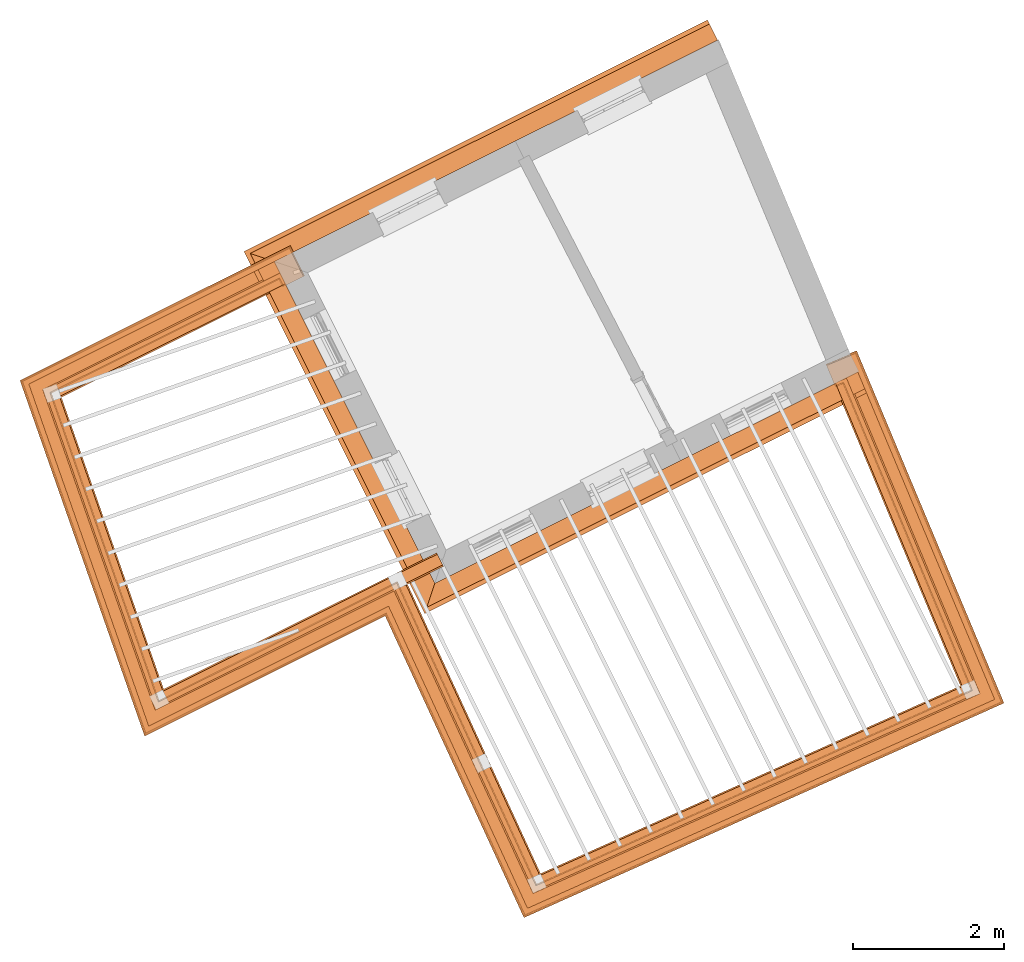
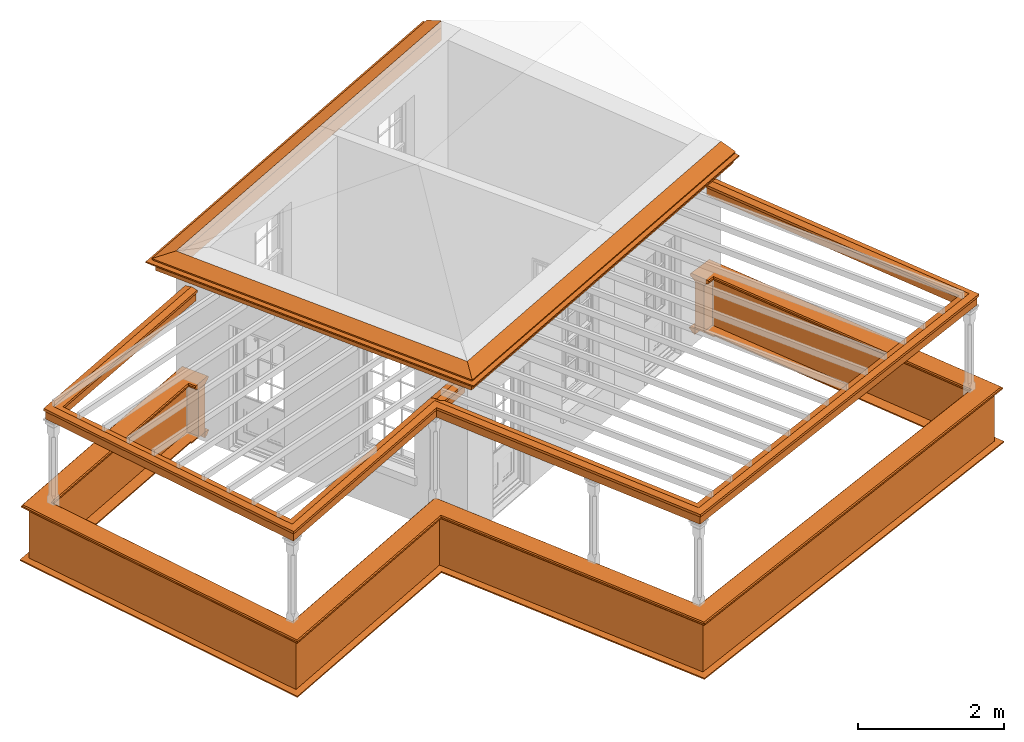
# One storey, part 6 of 7: 9 proxies.
"""IFC2X3 building model written with IfcOpenShell, lengths in metres."""

import ifcopenshell
import ifcopenshell.guid

model = None  # the IFC model being written
_history = None  # IfcOwnerHistory: only IFC2X3 demands one
_inside = {}  # id of a spatial element -> (the spatial element, [elements in it])
_under = {}  # id of a project, library or spatial element -> (it, [spatial elements below it])
_declared = {}  # id of a project -> (the project, [libraries it declares])
_typed = {}  # id of a type object -> (the type object, [elements of that type])
_made_of = {}  # id of a material, layer set ... -> (it, [elements and type objects made of it])


def new_model(schema):
    """Start an empty IFC model of exactly this schema.

    Asked for "IFC4X3", IfcOpenShell would pick the latest addendum, in which some entities
    have other attributes; the version numbers below select the first issue.
    IFC2X3 requires an IfcOwnerHistory on every rooted entity: one is made here for all.
    """
    global model, _history
    if schema == "IFC4X3":
        model = ifcopenshell.file(schema_version=(4, 3, 0, 0))
    else:
        model = ifcopenshell.file(schema=schema)
    _inside.clear()
    _under.clear()
    _declared.clear()
    _typed.clear()
    _made_of.clear()
    _history = None
    if model.schema == "IFC2X3":
        org = make("IfcOrganization", Name="unknown")
        user = make(
            "IfcPersonAndOrganization",
            ThePerson=make("IfcPerson", FamilyName="unknown"),
            TheOrganization=org,
        )
        app = make(
            "IfcApplication",
            ApplicationDeveloper=org,
            Version="unknown",
            ApplicationFullName="unknown",
            ApplicationIdentifier="unknown",
        )
        _history = make(
            "IfcOwnerHistory",
            OwningUser=user,
            OwningApplication=app,
            ChangeAction="ADDED",
            CreationDate=0,
        )
    return model


def make(cls, **values):
    """One entity of the class cls with the attributes given. An attribute that is None is left unset."""
    return model.create_entity(
        cls, **{name: value for name, value in values.items() if value is not None}
    )


def entity(cls, *values):
    """Any entity or typed value of the class cls, its attributes in the order of the schema. None: left unset."""
    e = model.create_entity(cls)
    for i, value in enumerate(values):
        if value is not None:
            e[i] = value
    return e


def rooted(cls, **values):
    """An entity with a GlobalId (a new one), such as an element, a storey or a relation."""
    return make(cls, GlobalId=ifcopenshell.guid.new(), OwnerHistory=_history, **values)


def si_unit(unit_type, name, prefix=None):
    """IfcSIUnit, for example si_unit("LENGTHUNIT", "METRE", prefix="MILLI")."""
    return make("IfcSIUnit", UnitType=unit_type, Prefix=prefix, Name=name)


def assignment(units):
    """IfcUnitAssignment: the units of a project."""
    return None if units is None else make("IfcUnitAssignment", Units=units)


def point(xyz):
    """IfcCartesianPoint."""
    return None if xyz is None else make("IfcCartesianPoint", Coordinates=xyz)


def direction(xyz):
    """IfcDirection."""
    return None if xyz is None else make("IfcDirection", DirectionRatios=xyz)


def frame(location, z_axis=None, x_axis=None):
    """IfcAxis2Placement3D, a coordinate frame: its origin and axes. An axis left out is left unset."""
    return make(
        "IfcAxis2Placement3D",
        Location=point(location),
        Axis=direction(z_axis),
        RefDirection=direction(x_axis),
    )


def origin():
    """The frame at (0, 0, 0) with its axes left unset."""
    return frame((0.0, 0.0, 0.0))


def place(relative_to, where):
    """IfcLocalPlacement: puts the frame where relative to a parent placement (None: the world)."""
    return make(
        "IfcLocalPlacement", PlacementRelTo=relative_to, RelativePlacement=where
    )


def context(
    kind, dimensions, precision=None, world=None, true_north=None, identifier=None
):
    """IfcGeometricRepresentationContext, for example the 3D "Model" context."""
    return make(
        "IfcGeometricRepresentationContext",
        ContextIdentifier=identifier,
        ContextType=kind,
        CoordinateSpaceDimension=dimensions,
        Precision=precision,
        WorldCoordinateSystem=world,
        TrueNorth=true_north,
    )


def subcontext(parent, identifier, kind, view, scale=None):
    """IfcGeometricRepresentationSubContext, for example "Body" below "Model"."""
    return make(
        "IfcGeometricRepresentationSubContext",
        ContextIdentifier=identifier,
        ContextType=kind,
        ParentContext=parent,
        TargetScale=scale,
        TargetView=view,
    )


def project(units=None, contexts=None):
    """IfcProject with its units and contexts."""
    return rooted(
        "IfcProject",
        Name="project",
        RepresentationContexts=contexts,
        UnitsInContext=assignment(units),
    )


def spatial(cls, under=None, at=None, **own):
    """A site, building, storey or space (cls), placed at a placement, below another one or the project."""
    s = rooted(cls, ObjectPlacement=at, **own)
    if under is not None:
        _under.setdefault(under.id(), (under, []))[1].append(s)
    return s


def shape(context_of_items, identifier, shape_type, items):
    """IfcShapeRepresentation: the items that make up one representation, for example the "Body"."""
    return make(
        "IfcShapeRepresentation",
        ContextOfItems=context_of_items,
        RepresentationIdentifier=identifier,
        RepresentationType=shape_type,
        Items=items,
    )


def made_of(thing, what):
    """Note that an element or type object is made of a material, layer set ...; save() writes the relation."""
    if what is not None:
        _made_of.setdefault(what.id(), (what, []))[1].append(thing)
    return thing


def element(
    cls,
    number,
    at=None,
    inside=None,
    cuts=None,
    type_object=None,
    material=None,
    context=None,
    identifier="Body",
    shape_type=None,
    held_by="IfcProductDefinitionShape",
    body=None,
    shapes=None,
    **own,
):
    """One element of the class cls, such as IfcWall. Its Tag is "e" and its number.

    at: its placement. inside: the storey or other place that contains it. cuts: it is an
    opening in that element (IfcRelVoidsElement). A single representation is given by context,
    identifier, shape_type and body (its items); several are given by shapes. held_by: the class
    of the entity that holds the representations. save() writes the other relations.
    """
    e = rooted(cls, Tag="e%d" % number, ObjectPlacement=at, **own)
    if body is not None:
        shapes = [shape(context, identifier, shape_type, body)]
    if shapes is not None:
        e.Representation = make(held_by, Representations=shapes)
    if inside is not None:
        _inside.setdefault(inside.id(), (inside, []))[1].append(e)
    if cuts is not None:
        rooted(
            "IfcRelVoidsElement", RelatingBuildingElement=cuts, RelatedOpeningElement=e
        )
    if type_object is not None:
        _typed.setdefault(type_object.id(), (type_object, []))[1].append(e)
    return made_of(e, material)


def aggregate(whole, parts):
    """IfcRelAggregates: a whole, such as a stair, and the parts it consists of."""
    return rooted("IfcRelAggregates", RelatingObject=whole, RelatedObjects=parts)


def save(model, path):
    """Write the relations noted so far, then the file.

    IfcRelAggregates (storeys below a building ...), IfcRelContainedInSpatialStructure (elements
    in a storey), IfcRelDefinesByType, IfcRelAssociatesMaterial and IfcRelDeclares: one each for
    every whole, place, type object, material and project.
    """
    for whole, parts in _under.values():
        aggregate(whole, parts)
    for where, things in _inside.values():
        rooted(
            "IfcRelContainedInSpatialStructure",
            RelatedElements=things,
            RelatingStructure=where,
        )
    for kind, things in _typed.values():
        rooted("IfcRelDefinesByType", RelatedObjects=things, RelatingType=kind)
    for what, things in _made_of.values():
        rooted("IfcRelAssociatesMaterial", RelatedObjects=things, RelatingMaterial=what)
    for by, libraries in _declared.values():
        rooted("IfcRelDeclares", RelatingContext=by, RelatedDefinitions=libraries)
    model.write(path)


model = new_model("IFC2X3")

# Units and contexts
model_context = context("Model", 3, world=origin())
body_context = subcontext(model_context, "Body", "Model", "MODEL_VIEW")
ifc_project = project(units=[si_unit("PLANEANGLEUNIT", "RADIAN"), si_unit("MASSUNIT", "GRAM", prefix="KILO"), si_unit("FORCEUNIT", "NEWTON", prefix="KILO"), si_unit("LENGTHUNIT", "METRE")], contexts=[model_context])

# Site, building, storey
site_placement = place(None, origin())
site = spatial("IfcSite", under=ifc_project, at=site_placement, CompositionType="ELEMENT")
building_placement = place(None, origin())
building = spatial("IfcBuilding", under=site, at=building_placement, Name="Building plot-8", CompositionType="ELEMENT")
storey_placement = place(None, frame((0.0, 0.0, 6.3)))
storey = spatial("IfcBuildingStorey", under=building, at=storey_placement, Name="Floor 2", CompositionType="ELEMENT", Elevation=6.3)

# Proxies
proxy_1_placement = place(storey_placement, frame((0.0, 0.0, 3.0)))
axis2_placement3_d_1 = entity("IfcAxis2Placement3D", entity("IfcCartesianPoint", [0.0, 0.0, 0.0]))
element("IfcBuildingElementProxy", 1, at=proxy_1_placement, inside=storey, Name="eaves", CompositionType="ELEMENT", context=body_context, shape_type="SweptSolid", held_by="IfcProductRepresentation", body=[
    entity("IfcSurfaceCurveSweptAreaSolid", entity("IfcArbitraryClosedProfileDef", "AREA", None, entity("IfcPolyline", [entity("IfcCartesianPoint", [-0.11, 0.25]), entity("IfcCartesianPoint", [-0.33, 0.25]), entity("IfcCartesianPoint", [-0.33, 0.265]), entity("IfcCartesianPoint", [-0.318, 0.268]), entity("IfcCartesianPoint", [-0.309, 0.274]), entity("IfcCartesianPoint", [-0.303, 0.283]), entity("IfcCartesianPoint", [-0.3, 0.295]), entity("IfcCartesianPoint", [-0.285, 0.295]), entity("IfcCartesianPoint", [-0.285, 0.455]), entity("IfcCartesianPoint", [-0.205, 0.455]), entity("IfcCartesianPoint", [-0.205, 0.47]), entity("IfcCartesianPoint", [-0.19, 0.47]), entity("IfcCartesianPoint", [-0.189, 0.483]), entity("IfcCartesianPoint", [-0.186, 0.494]), entity("IfcCartesianPoint", [-0.179, 0.506]), entity("IfcCartesianPoint", [-0.17, 0.514]), entity("IfcCartesianPoint", [-0.16, 0.52]), entity("IfcCartesianPoint", [-0.149, 0.529]), entity("IfcCartesianPoint", [-0.143, 0.539]), entity("IfcCartesianPoint", [-0.14, 0.55]), entity("IfcCartesianPoint", [-0.12, 0.55]), entity("IfcCartesianPoint", [-0.11, 0.48]), entity("IfcCartesianPoint", [-0.11, 0.25])])), axis2_placement3_d_1, entity("IfcPolyline", [entity("IfcCartesianPoint", [28.16190590808, 20.0069247398743]), entity("IfcCartesianPoint", [22.4976810156354, 17.1790956715868]), entity("IfcCartesianPoint", [24.4075412546338, 13.3535893748517]), entity("IfcCartesianPoint", [29.8153964687674, 16.0534274748564])]), 0.0, 1.0, entity("IfcPlane", axis2_placement3_d_1)),
])
proxy_2_placement = place(storey_placement, frame((0.0, 0.0, 3.0)))
axis2_placement3_d_2 = entity("IfcAxis2Placement3D", entity("IfcCartesianPoint", [0.0, 0.0, 0.0]))
element("IfcBuildingElementProxy", 2, at=proxy_2_placement, inside=storey, Name="eaves", CompositionType="ELEMENT", context=body_context, shape_type="SweptSolid", held_by="IfcProductRepresentation", body=[
    entity("IfcSurfaceCurveSweptAreaSolid", entity("IfcArbitraryClosedProfileDef", "AREA", None, entity("IfcPolyline", [entity("IfcCartesianPoint", [-0.11, 0.25]), entity("IfcCartesianPoint", [-0.11, 0.48]), entity("IfcCartesianPoint", [-0.08, 0.49]), entity("IfcCartesianPoint", [0.0, 0.25]), entity("IfcCartesianPoint", [-0.11, 0.25])])), axis2_placement3_d_2, entity("IfcPolyline", [entity("IfcCartesianPoint", [28.16190590808, 20.0069247398743]), entity("IfcCartesianPoint", [22.4976810156354, 17.1790956715868]), entity("IfcCartesianPoint", [24.4075412546338, 13.3535893748517]), entity("IfcCartesianPoint", [29.8153964687674, 16.0534274748564])]), 0.0, 1.0, entity("IfcPlane", axis2_placement3_d_2)),
])
proxy_3_placement = place(storey_placement, origin())
axis2_placement3_d_3 = entity("IfcAxis2Placement3D", entity("IfcCartesianPoint", [0.0, 0.0, 0.0]))
element("IfcBuildingElementProxy", 3, at=proxy_3_placement, inside=storey, Name="parapet", CompositionType="ELEMENT", context=body_context, shape_type="SweptSolid", held_by="IfcProductRepresentation", body=[
    entity("IfcSurfaceCurveSweptAreaSolid", entity("IfcArbitraryClosedProfileDef", "AREA", None, entity("IfcPolyline", [entity("IfcCartesianPoint", [0.0, 0.25]), entity("IfcCartesianPoint", [0.795, 0.25]), entity("IfcCartesianPoint", [0.795, 0.09]), entity("IfcCartesianPoint", [0.02, 0.09]), entity("IfcCartesianPoint", [0.02, -0.08]), entity("IfcCartesianPoint", [0.0, -0.08]), entity("IfcCartesianPoint", [0.0, 0.25])])), axis2_placement3_d_3, entity("IfcPolyline", [entity("IfcCartesianPoint", [22.2649919652668, 16.951157509274]), entity("IfcCartesianPoint", [22.2203247406861, 17.0406272753867]), entity("IfcCartesianPoint", [19.2103300053526, 15.5379061141344]), entity("IfcCartesianPoint", [20.6359073827199, 11.4706246090701]), entity("IfcCartesianPoint", [23.7996751591945, 13.0501160052469]), entity("IfcCartesianPoint", [25.6491830633519, 9.02936513625309]), entity("IfcCartesianPoint", [31.4063653367344, 11.6029458586881]), entity("IfcCartesianPoint", [29.7113348769368, 15.6557650560022]), entity("IfcCartesianPoint", [29.6190786326134, 15.6171802742438])]), 0.0, 1.0, entity("IfcPlane", axis2_placement3_d_3)),
])
proxy_4_placement = place(storey_placement, origin())
axis2_placement3_d_4 = entity("IfcAxis2Placement3D", entity("IfcCartesianPoint", [0.0, 0.0, 0.0]))
element("IfcBuildingElementProxy", 4, at=proxy_4_placement, inside=storey, Name="parapet", CompositionType="ELEMENT", context=body_context, shape_type="SweptSolid", held_by="IfcProductRepresentation", body=[
    entity("IfcSurfaceCurveSweptAreaSolid", entity("IfcArbitraryClosedProfileDef", "AREA", None, entity("IfcPolyline", [entity("IfcCartesianPoint", [0.795, 0.265]), entity("IfcCartesianPoint", [0.807, 0.268]), entity("IfcCartesianPoint", [0.816, 0.274]), entity("IfcCartesianPoint", [0.822, 0.283]), entity("IfcCartesianPoint", [0.825, 0.295]), entity("IfcCartesianPoint", [0.84, 0.295]), entity("IfcCartesianPoint", [0.84, 0.305]), entity("IfcCartesianPoint", [0.842, 0.317]), entity("IfcCartesianPoint", [0.849, 0.326]), entity("IfcCartesianPoint", [0.858, 0.333]), entity("IfcCartesianPoint", [0.87, 0.335]), entity("IfcCartesianPoint", [0.882, 0.333]), entity("IfcCartesianPoint", [0.891, 0.326]), entity("IfcCartesianPoint", [0.898, 0.317]), entity("IfcCartesianPoint", [0.9, 0.305]), entity("IfcCartesianPoint", [0.9, 0.035]), entity("IfcCartesianPoint", [0.898, 0.023]), entity("IfcCartesianPoint", [0.891, 0.014]), entity("IfcCartesianPoint", [0.882, 0.007]), entity("IfcCartesianPoint", [0.87, 0.005]), entity("IfcCartesianPoint", [0.858, 0.007]), entity("IfcCartesianPoint", [0.849, 0.014]), entity("IfcCartesianPoint", [0.842, 0.023]), entity("IfcCartesianPoint", [0.84, 0.035]), entity("IfcCartesianPoint", [0.84, 0.045]), entity("IfcCartesianPoint", [0.825, 0.045]), entity("IfcCartesianPoint", [0.822, 0.057]), entity("IfcCartesianPoint", [0.816, 0.066]), entity("IfcCartesianPoint", [0.807, 0.072]), entity("IfcCartesianPoint", [0.795, 0.075]), entity("IfcCartesianPoint", [0.795, 0.265])])), axis2_placement3_d_4, entity("IfcPolyline", [entity("IfcCartesianPoint", [22.2649919652668, 16.951157509274]), entity("IfcCartesianPoint", [22.2203247406861, 17.0406272753867]), entity("IfcCartesianPoint", [19.2103300053526, 15.5379061141344]), entity("IfcCartesianPoint", [20.6359073827199, 11.4706246090701]), entity("IfcCartesianPoint", [23.7996751591945, 13.0501160052469]), entity("IfcCartesianPoint", [25.6491830633519, 9.02936513625309]), entity("IfcCartesianPoint", [31.4063653367344, 11.6029458586881]), entity("IfcCartesianPoint", [29.7113348769368, 15.6557650560022]), entity("IfcCartesianPoint", [29.6190786326134, 15.6171802742438])]), 0.0, 1.0, entity("IfcPlane", axis2_placement3_d_4)),
])
proxy_5_placement = place(storey_placement, origin())
axis2_placement3_d_5 = entity("IfcAxis2Placement3D", entity("IfcCartesianPoint", [0.0, 0.0, 0.0]))
element("IfcBuildingElementProxy", 5, at=proxy_5_placement, inside=storey, Name="parapet", CompositionType="ELEMENT", context=body_context, shape_type="SweptSolid", held_by="IfcProductRepresentation", body=[
    entity("IfcSurfaceCurveSweptAreaSolid", entity("IfcArbitraryClosedProfileDef", "AREA", None, entity("IfcPolyline", [entity("IfcCartesianPoint", [-0.1, 0.25]), entity("IfcCartesianPoint", [-0.1, 0.265]), entity("IfcCartesianPoint", [-0.085, 0.265]), entity("IfcCartesianPoint", [-0.084, 0.278]), entity("IfcCartesianPoint", [-0.081, 0.289]), entity("IfcCartesianPoint", [-0.074, 0.301]), entity("IfcCartesianPoint", [-0.065, 0.309]), entity("IfcCartesianPoint", [-0.055, 0.315]), entity("IfcCartesianPoint", [-0.044, 0.324]), entity("IfcCartesianPoint", [-0.038, 0.334]), entity("IfcCartesianPoint", [-0.035, 0.345]), entity("IfcCartesianPoint", [-0.015, 0.345]), entity("IfcCartesianPoint", [0.0, 0.25]), entity("IfcCartesianPoint", [-0.1, 0.25])])), axis2_placement3_d_5, entity("IfcPolyline", [entity("IfcCartesianPoint", [22.2649919652668, 16.951157509274]), entity("IfcCartesianPoint", [22.2203247406861, 17.0406272753867]), entity("IfcCartesianPoint", [19.2103300053526, 15.5379061141344]), entity("IfcCartesianPoint", [20.6359073827199, 11.4706246090701]), entity("IfcCartesianPoint", [23.7996751591945, 13.0501160052469]), entity("IfcCartesianPoint", [25.6491830633519, 9.02936513625309]), entity("IfcCartesianPoint", [31.4063653367344, 11.6029458586881]), entity("IfcCartesianPoint", [29.7113348769368, 15.6557650560022]), entity("IfcCartesianPoint", [29.6190786326134, 15.6171802742438])]), 0.0, 1.0, entity("IfcPlane", axis2_placement3_d_5)),
])
proxy_6_placement = place(storey_placement, frame((0.0, 0.0, 3.0)))
axis2_placement3_d_6 = entity("IfcAxis2Placement3D", entity("IfcCartesianPoint", [0.0, 0.0, 0.0]))
element("IfcBuildingElementProxy", 6, at=proxy_6_placement, inside=storey, Name="pergola beam", CompositionType="ELEMENT", context=body_context, shape_type="SweptSolid", held_by="IfcProductRepresentation", body=[
    entity("IfcSurfaceCurveSweptAreaSolid", entity("IfcArbitraryClosedProfileDef", "AREA", None, entity("IfcPolyline", [entity("IfcCartesianPoint", [-0.7, -0.08]), entity("IfcCartesianPoint", [-0.7, 0.08]), entity("IfcCartesianPoint", [-0.56, 0.08]), entity("IfcCartesianPoint", [-0.56, -0.08]), entity("IfcCartesianPoint", [-0.7, -0.08])])), axis2_placement3_d_6, entity("IfcPolyline", [entity("IfcCartesianPoint", [22.2740066003537, 17.0674276101351]), entity("IfcCartesianPoint", [19.2103300053526, 15.5379061141344]), entity("IfcCartesianPoint", [20.6359073827199, 11.4706246090701]), entity("IfcCartesianPoint", [23.7996751591945, 13.0501160052469]), entity("IfcCartesianPoint", [25.6491830633519, 9.02936513625309]), entity("IfcCartesianPoint", [31.4063653367344, 11.6029458586881]), entity("IfcCartesianPoint", [29.6881840078817, 15.7111188025962])]), 0.0, 1.0, entity("IfcPlane", axis2_placement3_d_6)),
])
proxy_7_placement = place(storey_placement, frame((0.0, 0.0, 3.0)))
axis2_placement3_d_7 = entity("IfcAxis2Placement3D", entity("IfcCartesianPoint", [0.0, 0.0, 0.0]))
element("IfcBuildingElementProxy", 7, at=proxy_7_placement, inside=storey, Name="pergola beam", CompositionType="ELEMENT", context=body_context, shape_type="SweptSolid", held_by="IfcProductRepresentation", body=[
    entity("IfcSurfaceCurveSweptAreaSolid", entity("IfcArbitraryClosedProfileDef", "AREA", None, entity("IfcPolyline", [entity("IfcCartesianPoint", [-0.5, 0.0]), entity("IfcCartesianPoint", [-0.52, -0.1]), entity("IfcCartesianPoint", [-0.56, -0.1]), entity("IfcCartesianPoint", [-0.56, 0.1]), entity("IfcCartesianPoint", [-0.52, 0.1]), entity("IfcCartesianPoint", [-0.5, 0.0])])), axis2_placement3_d_7, entity("IfcPolyline", [entity("IfcCartesianPoint", [22.2740066003537, 17.0674276101351]), entity("IfcCartesianPoint", [19.2103300053526, 15.5379061141344]), entity("IfcCartesianPoint", [20.6359073827199, 11.4706246090701]), entity("IfcCartesianPoint", [23.7996751591945, 13.0501160052469]), entity("IfcCartesianPoint", [25.6491830633519, 9.02936513625309]), entity("IfcCartesianPoint", [31.4063653367344, 11.6029458586881]), entity("IfcCartesianPoint", [29.6881840078817, 15.7111188025962])]), 0.0, 1.0, entity("IfcPlane", axis2_placement3_d_7)),
])
proxy_8_placement = place(storey_placement, frame((0.0, 0.0, 3.0)))
axis2_placement3_d_8 = entity("IfcAxis2Placement3D", entity("IfcCartesianPoint", [0.0, 0.0, 0.0]))
element("IfcBuildingElementProxy", 8, at=proxy_8_placement, inside=storey, Name="pergola beam", CompositionType="ELEMENT", context=body_context, shape_type="SweptSolid", held_by="IfcProductRepresentation", body=[
    entity("IfcSurfaceCurveSweptAreaSolid", entity("IfcArbitraryClosedProfileDef", "AREA", None, entity("IfcPolyline", [entity("IfcCartesianPoint", [-0.7, -0.08]), entity("IfcCartesianPoint", [-0.7, 0.08]), entity("IfcCartesianPoint", [-0.56, 0.08]), entity("IfcCartesianPoint", [-0.56, -0.08]), entity("IfcCartesianPoint", [-0.7, -0.08])])), axis2_placement3_d_8, entity("IfcPolyline", [entity("IfcCartesianPoint", [23.8444100422508, 13.0724496175372]), entity("IfcCartesianPoint", [24.3628063715775, 13.3312557625614])]), 0.0, 1.0, entity("IfcPlane", axis2_placement3_d_8)),
])
proxy_9_placement = place(storey_placement, frame((0.0, 0.0, 3.0)))
axis2_placement3_d_9 = entity("IfcAxis2Placement3D", entity("IfcCartesianPoint", [0.0, 0.0, 0.0]))
element("IfcBuildingElementProxy", 9, at=proxy_9_placement, inside=storey, Name="pergola beam", CompositionType="ELEMENT", context=body_context, shape_type="SweptSolid", held_by="IfcProductRepresentation", body=[
    entity("IfcSurfaceCurveSweptAreaSolid", entity("IfcArbitraryClosedProfileDef", "AREA", None, entity("IfcPolyline", [entity("IfcCartesianPoint", [-0.5, 0.0]), entity("IfcCartesianPoint", [-0.52, -0.1]), entity("IfcCartesianPoint", [-0.56, -0.1]), entity("IfcCartesianPoint", [-0.56, 0.1]), entity("IfcCartesianPoint", [-0.52, 0.1]), entity("IfcCartesianPoint", [-0.5, 0.0])])), axis2_placement3_d_9, entity("IfcPolyline", [entity("IfcCartesianPoint", [23.8444100422508, 13.0724496175372]), entity("IfcCartesianPoint", [24.3628063715775, 13.3312557625614])]), 0.0, 1.0, entity("IfcPlane", axis2_placement3_d_9)),
])

save(model, "model.ifc")
